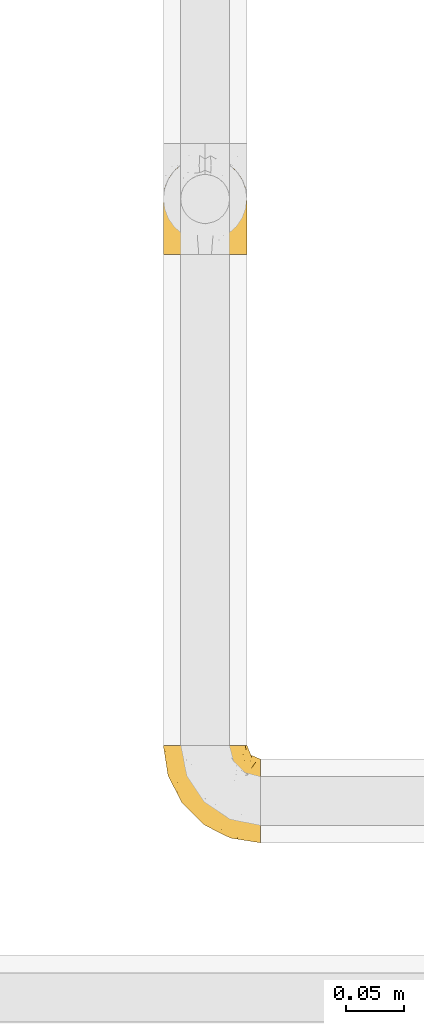
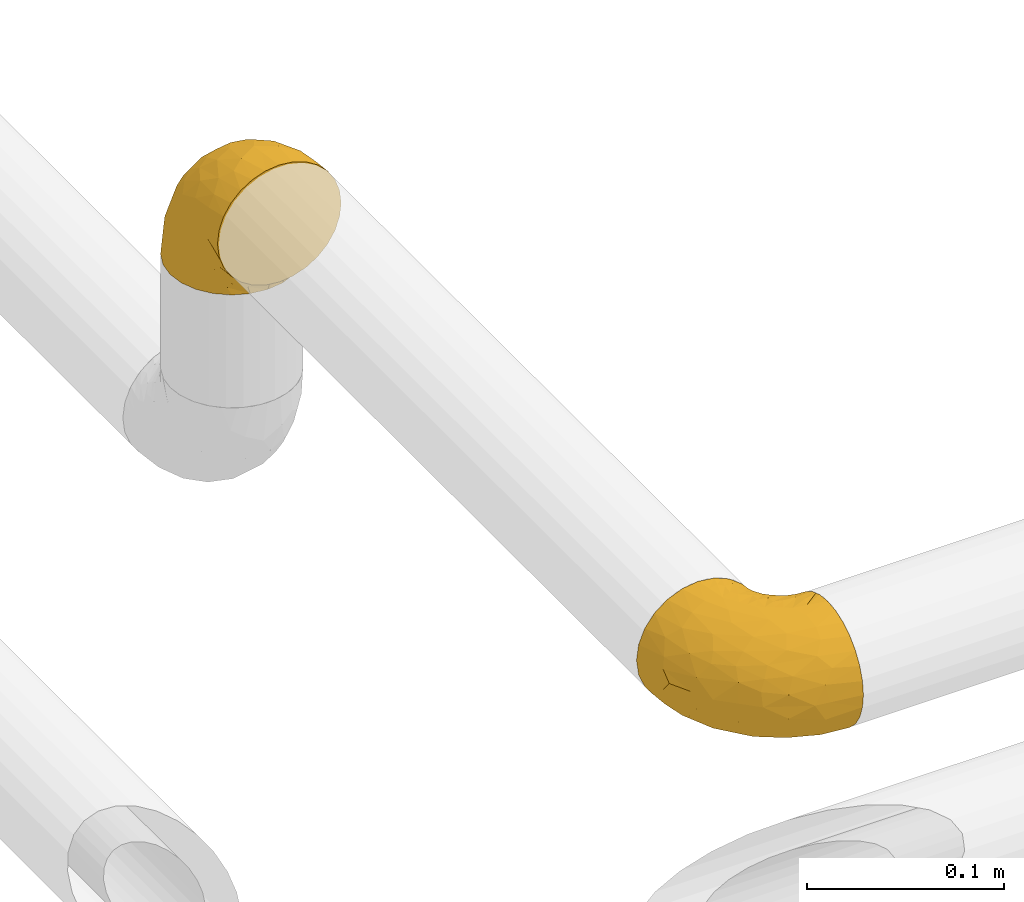
# One storey, part 8 of 39: 2 coverings.
"""IFC2X3 building model written with IfcOpenShell, lengths in millimetres."""

from ifc_helpers import new_model, entity, si_unit, converted_unit, derived_unit, direction, frame, origin, place, context, subcontext, project, spatial, faceted_brep, element, save


model = new_model("IFC2X3")

# Units and contexts
model_context = context("Model", 3, precision=0.01, world=origin(), true_north=direction((6.12303176911189e-17, 1.0)))
body_context = subcontext(model_context, "Body", "Model", "MODEL_VIEW")
ifc_project = project(units=[si_unit("LENGTHUNIT", "METRE", prefix="MILLI"), si_unit("AREAUNIT", "SQUARE_METRE"), si_unit("VOLUMEUNIT", "CUBIC_METRE"), converted_unit("PLANEANGLEUNIT", "DEGREE", entity("IfcRatioMeasure", 0.0174532925199433), si_unit("PLANEANGLEUNIT", "RADIAN"), dimensions=[0, 0, 0, 0, 0, 0, 0]), si_unit("MASSUNIT", "GRAM", prefix="KILO"), derived_unit("MASSDENSITYUNIT", [(si_unit("MASSUNIT", "GRAM", prefix="KILO"), 1), (si_unit("LENGTHUNIT", "METRE"), -3)]), derived_unit("MOMENTOFINERTIAUNIT", [(si_unit("LENGTHUNIT", "METRE"), 4)]), si_unit("TIMEUNIT", "SECOND"), si_unit("FREQUENCYUNIT", "HERTZ"), si_unit("THERMODYNAMICTEMPERATUREUNIT", "DEGREE_CELSIUS"), derived_unit("THERMALTRANSMITTANCEUNIT", [(si_unit("MASSUNIT", "GRAM", prefix="KILO"), 1), (si_unit("THERMODYNAMICTEMPERATUREUNIT", "KELVIN"), -1), (si_unit("TIMEUNIT", "SECOND"), -3)]), derived_unit("VOLUMETRICFLOWRATEUNIT", [(si_unit("LENGTHUNIT", "METRE"), 3), (si_unit("TIMEUNIT", "SECOND"), -1)]), derived_unit("MASSFLOWRATEUNIT", [(si_unit("MASSUNIT", "GRAM", prefix="KILO"), 1), (si_unit("TIMEUNIT", "SECOND"), -1)]), derived_unit("ROTATIONALFREQUENCYUNIT", [(si_unit("TIMEUNIT", "SECOND"), -1)]), si_unit("ELECTRICCURRENTUNIT", "AMPERE"), si_unit("ELECTRICVOLTAGEUNIT", "VOLT"), si_unit("POWERUNIT", "WATT"), si_unit("FORCEUNIT", "NEWTON", prefix="KILO"), si_unit("ILLUMINANCEUNIT", "LUX"), si_unit("LUMINOUSFLUXUNIT", "LUMEN"), si_unit("LUMINOUSINTENSITYUNIT", "CANDELA"), derived_unit("USERDEFINED", [(si_unit("MASSUNIT", "GRAM", prefix="KILO"), -1), (si_unit("LENGTHUNIT", "METRE"), -2), (si_unit("TIMEUNIT", "SECOND"), 3), (si_unit("LUMINOUSFLUXUNIT", "LUMEN"), 1)]), derived_unit("LINEARVELOCITYUNIT", [(si_unit("LENGTHUNIT", "METRE"), 1), (si_unit("TIMEUNIT", "SECOND"), -1)]), si_unit("PRESSUREUNIT", "PASCAL"), derived_unit("USERDEFINED", [(si_unit("LENGTHUNIT", "METRE"), -2), (si_unit("MASSUNIT", "GRAM", prefix="KILO"), 1), (si_unit("TIMEUNIT", "SECOND"), -2)]), derived_unit("LINEARFORCEUNIT", [(si_unit("MASSUNIT", "GRAM", prefix="KILO"), 1), (si_unit("LENGTHUNIT", "METRE"), 1), (si_unit("TIMEUNIT", "SECOND"), -2), (si_unit("LENGTHUNIT", "METRE"), -1)]), derived_unit("PLANARFORCEUNIT", [(si_unit("MASSUNIT", "GRAM", prefix="KILO"), 1), (si_unit("LENGTHUNIT", "METRE"), 1), (si_unit("TIMEUNIT", "SECOND"), -2), (si_unit("LENGTHUNIT", "METRE"), -2)])], contexts=[model_context])

# Site, building, storey
site_placement = place(None, origin())
site = spatial("IfcSite", under=ifc_project, at=site_placement, CompositionType="ELEMENT")
building_placement = place(site_placement, origin())
building = spatial("IfcBuilding", under=site, at=building_placement, CompositionType="ELEMENT")
storey_placement = place(building_placement, frame((0.0, 0.0, 24000.0)))
storey = spatial("IfcBuildingStorey", under=building, at=storey_placement, Name="07", CompositionType="ELEMENT", Elevation=24000.0)

# Coverings
covering_1_placement = place(storey_placement, frame((31392.2, 2072.36, 2776.36)))
element("IfcCovering", 1, at=covering_1_placement, inside=storey, Name=":ADSK_", ObjectType=":ADSK_", PredefinedType="INSULATION", context=body_context, shape_type="Brep", body=[
    faceted_brep([(74.0, 1.6, 49.6), (73.09, 1.6, 57.65), (70.41, 1.6, 65.31), (66.09, 1.6, 72.17), (60.36, 1.6, 77.9), (53.5, 1.6, 82.21), (45.85, 1.6, 84.89), (37.8, 1.6, 85.8), (29.74, 1.6, 84.89), (22.08, 1.6, 82.21), (15.22, 1.6, 77.89), (9.49, 1.6, 72.16), (5.18, 1.6, 65.3), (2.5, 1.6, 57.65), (1.6, 1.6, 49.6), (2.19, 1.6, 44.33), (2.5, 1.6, 41.54), (3.84, 1.6, 37.71), (5.18, 1.6, 33.88), (9.5, 1.6, 27.02), (15.23, 1.6, 21.29), (22.09, 1.6, 16.98), (29.74, 1.6, 14.3), (37.8, 1.6, 13.4), (45.85, 1.6, 14.3), (53.51, 1.6, 16.98), (60.37, 1.6, 21.3), (66.1, 1.6, 27.03), (70.41, 1.6, 33.89), (71.75, 1.6, 37.72), (73.09, 1.6, 41.54), (73.4, 1.6, 44.33), (28.43, 14.63, 1.6), (19.7, 18.25, 1.6), (12.2, 24.0, 1.6), (9.32, 27.75, 1.6), (6.45, 31.5, 1.6), (4.64, 35.86, 1.6), (2.83, 40.23, 1.6), (2.29, 44.31, 1.6), (1.94, 46.95, 1.6), (1.6, 49.6, 1.6), (2.83, 58.96, 1.6), (6.45, 67.7, 1.6), (12.2, 75.19, 1.6), (19.7, 80.95, 1.6), (28.43, 84.56, 1.6), (37.8, 85.8, 1.6), (47.16, 84.56, 1.6), (55.9, 80.95, 1.6), (63.39, 75.19, 1.6), (69.15, 67.7, 1.6), (72.76, 58.96, 1.6), (74.0, 49.6, 1.6), (73.3, 44.31, 1.6), (72.76, 40.23, 1.6), (70.95, 35.86, 1.6), (69.15, 31.5, 1.6), (66.27, 27.75, 1.6), (63.39, 24.0, 1.6), (55.9, 18.25, 1.6), (47.16, 14.63, 1.6), (37.8, 13.4, 1.6), (50.11, 59.61, 59.61), (37.8, 60.4, 60.4), (46.44, 51.32, 68.25), (37.8, 81.67, 27.61), (44.03, 82.49, 22.94), (37.8, 82.98, 19.4), (47.59, 73.87, 42.09), (57.17, 73.39, 33.53), (50.38, 81.11, 21.38), (58.65, 77.75, 16.47), (73.37, 16.46, 54.23), (71.27, 51.34, 38.23), (70.16, 63.37, 19.11), (66.97, 61.46, 36.76), (73.22, 54.83, 17.03), (74.0, 45.94, 19.96), (74.0, 47.42, 12.51), (74.0, 47.97, 9.78), (74.0, 48.51, 7.05), (64.86, 70.77, 21.71), (70.93, 15.75, 62.55), (45.19, 39.56, 75.89), (48.57, 21.48, 81.72), (54.32, 36.01, 74.04), (72.94, 34.58, 47.66), (74.0, 19.96, 45.94), (74.0, 23.86, 43.34), (74.0, 27.75, 40.74), (74.0, 31.64, 38.14), (74.0, 35.54, 35.54), (68.72, 46.13, 51.41), (73.34, 48.41, 30.21), (67.28, 16.74, 68.91), (61.7, 21.75, 74.03), (55.94, 16.31, 79.54), (37.8, 19.4, 82.98), (53.02, 48.77, 67.24), (57.31, 58.66, 55.48), (74.0, 7.05, 48.51), (74.0, 12.51, 47.42), (64.86, 34.87, 65.49), (59.15, 45.71, 64.99), (70.05, 30.95, 58.95), (55.98, 67.5, 45.7), (37.8, 75.69, 39.35), (63.54, 53.35, 53.72), (61.4, 64.73, 42.9), (37.8, 27.61, 81.67), (37.8, 51.09, 69.71), (37.8, 39.35, 75.69), (74.0, 38.14, 31.64), (74.0, 40.74, 27.75), (74.0, 43.34, 23.86), (37.8, 69.71, 51.09), (70.9, 30.92, 17.47), (69.2, 26.47, 18.36), (65.83, 24.1, 12.71), (73.31, 42.08, 7.84), (67.07, 27.56, 7.85), (62.53, 22.68, 6.14), (52.3, 12.9, 11.2), (54.94, 10.56, 14.99), (46.54, 9.38, 11.85), (72.14, 25.09, 29.62), (70.14, 24.56, 23.5), (73.22, 30.86, 29.66), (59.32, 15.4, 14.49), (56.36, 16.56, 9.51), (48.99, 14.21, 6.6), (58.36, 19.1, 6.61), (66.05, 6.65, 26.46), (61.56, 9.22, 20.83), (68.98, 13.56, 28.69), (73.26, 10.43, 41.38), (70.05, 32.68, 7.16), (73.39, 40.02, 16.97), (70.87, 33.01, 12.64), (61.17, 13.09, 18.4), (71.9, 11.85, 35.97), (65.19, 20.93, 16.38), (37.8, 6.64, 11.31), (46.04, 5.68, 13.68), (52.15, 5.7, 15.78), (66.57, 14.76, 24.06), (37.8, 9.94, 9.94), (73.34, 25.2, 35.3), (72.91, 19.66, 36.41), (37.8, 11.31, 6.64), (72.75, 39.13, 10.52), (66.28, 18.54, 20.86), (73.17, 37.21, 20.48), (72.08, 30.49, 23.69), (17.23, 19.1, 6.61), (26.6, 14.22, 6.59), (13.06, 22.68, 6.13), (1.6, 7.05, 48.51), (1.6, 12.51, 47.42), (29.56, 5.68, 13.67), (20.66, 10.57, 14.98), (23.45, 5.7, 15.78), (14.04, 9.22, 20.82), (1.6, 49.05, 4.32), (1.6, 47.42, 12.51), (1.6, 48.51, 7.05), (19.23, 16.56, 9.51), (23.3, 12.9, 11.19), (16.29, 15.39, 14.48), (8.09, 27.52, 10.19), (4.72, 33.0, 12.64), (5.54, 32.67, 7.16), (3.69, 11.86, 35.96), (2.84, 39.13, 10.52), (2.42, 37.21, 20.47), (4.69, 30.92, 17.47), (3.51, 30.49, 23.68), (2.2, 40.02, 16.97), (29.05, 9.38, 11.85), (2.29, 42.08, 7.84), (9.55, 6.65, 26.45), (14.43, 13.09, 18.39), (2.33, 10.43, 41.37), (9.32, 18.54, 20.85), (3.45, 25.08, 29.62), (5.45, 24.56, 23.5), (10.41, 20.93, 16.36), (2.81, 19.57, 35.87), (6.62, 13.56, 28.67), (1.6, 19.96, 45.94), (9.76, 24.1, 12.7), (9.03, 14.76, 24.04), (1.6, 40.74, 27.75), (4.15, 20.0, 30.95), (2.17, 25.27, 35.8), (1.6, 23.86, 43.34), (2.37, 30.85, 29.66), (1.6, 45.94, 19.96), (1.6, 43.34, 23.86), (6.39, 26.46, 18.36), (1.6, 38.14, 31.64), (1.6, 27.75, 40.74), (1.6, 35.54, 35.54), (1.6, 31.64, 38.14), (4.32, 51.33, 38.23), (2.37, 54.83, 17.03), (2.25, 48.41, 30.2), (16.43, 45.7, 64.98), (18.27, 58.67, 55.47), (12.04, 53.34, 53.71), (8.62, 61.46, 36.76), (6.87, 46.13, 51.4), (10.72, 34.86, 65.48), (2.64, 34.58, 47.66), (25.48, 59.61, 59.61), (19.59, 67.49, 45.69), (5.43, 63.37, 19.11), (31.57, 82.49, 22.94), (25.21, 81.11, 21.39), (5.53, 30.94, 58.94), (16.94, 77.75, 16.47), (10.73, 70.77, 21.71), (18.42, 73.39, 33.54), (21.26, 36.01, 74.04), (27.01, 21.48, 81.72), (30.39, 39.57, 75.89), (2.22, 16.45, 54.23), (13.88, 21.75, 74.02), (8.3, 16.74, 68.9), (28.0, 73.87, 42.09), (29.14, 51.31, 68.25), (22.56, 48.77, 67.24), (19.64, 16.32, 79.54), (14.18, 64.71, 42.91), (4.66, 15.75, 62.54)], [[[0, 1, 2, 3, 4, 5, 6, 7, 8, 9, 10, 11, 12, 13, 14, 15, 16, 17, 18, 19, 20, 21, 22, 23, 24, 25, 26, 27, 28, 29, 30, 31]], [[32, 33, 34, 35, 36, 37, 38, 39, 40, 41, 42, 43, 44, 45, 46, 47, 48, 49, 50, 51, 52, 53, 54, 55, 56, 57, 58, 59, 60, 61, 62]], [[63, 64, 65]], [[66, 67, 68]], [[69, 70, 71]], [[71, 70, 72]], [[73, 1, 0]], [[74, 75, 76]], [[49, 48, 71]], [[77, 78, 79, 80, 81, 53]], [[50, 82, 51]], [[72, 50, 49]], [[2, 1, 83]], [[84, 85, 86]], [[87, 88, 89, 90, 91, 92]], [[53, 52, 77]], [[93, 74, 76]], [[5, 85, 6]], [[94, 78, 77]], [[95, 3, 2]], [[95, 96, 3]], [[75, 51, 82]], [[85, 5, 97]], [[50, 72, 82]], [[97, 5, 4]], [[85, 98, 6]], [[94, 87, 92]], [[74, 77, 75]], [[99, 100, 63]], [[96, 4, 3]], [[73, 0, 101, 102, 88]], [[96, 103, 104]], [[48, 68, 67]], [[84, 99, 65]], [[105, 83, 73]], [[105, 95, 83]], [[100, 106, 63]], [[86, 96, 104]], [[97, 86, 85]], [[67, 107, 69]], [[100, 108, 109]], [[84, 110, 85]], [[93, 87, 74]], [[96, 95, 103]], [[69, 71, 67]], [[70, 69, 106]], [[4, 96, 97]], [[86, 97, 96]], [[83, 95, 2]], [[103, 95, 105]], [[93, 103, 105]], [[103, 108, 104]], [[75, 77, 52]], [[94, 77, 74]], [[51, 75, 52]], [[75, 82, 76]], [[109, 82, 70]], [[93, 76, 108]], [[88, 87, 73]], [[105, 73, 87]], [[84, 86, 99]], [[84, 111, 112, 110]], [[98, 85, 110]], [[98, 7, 6]], [[73, 83, 1]], [[71, 72, 49]], [[82, 72, 70]], [[87, 94, 74]], [[94, 92, 113, 114, 115, 78]], [[48, 47, 68]], [[48, 67, 71]], [[100, 104, 108]], [[99, 86, 104]], [[109, 108, 76]], [[100, 109, 106]], [[82, 109, 76]], [[106, 109, 70]], [[100, 99, 104]], [[99, 63, 65]], [[69, 116, 63]], [[111, 84, 65]], [[64, 63, 116]], [[64, 111, 65]], [[63, 106, 69]], [[103, 93, 108]], [[87, 93, 105]], [[107, 67, 66]], [[107, 116, 69]], [[117, 118, 119]], [[80, 120, 55]], [[121, 119, 122]], [[120, 56, 55]], [[123, 124, 125]], [[126, 127, 128]], [[101, 0, 31, 30, 102]], [[123, 129, 124]], [[130, 123, 131]], [[60, 122, 132]], [[133, 134, 135]], [[29, 28, 136]], [[132, 61, 60]], [[122, 60, 59]], [[137, 138, 139]], [[124, 129, 140]], [[133, 27, 26]], [[132, 131, 61]], [[141, 136, 28]], [[102, 29, 136]], [[119, 118, 142]], [[58, 137, 121]], [[141, 28, 27]], [[54, 53, 81, 80, 55]], [[23, 143, 144]], [[24, 145, 25]], [[25, 145, 134]], [[26, 25, 134]], [[135, 134, 146]], [[125, 143, 147]], [[124, 144, 125]], [[148, 90, 149]], [[124, 145, 144]], [[150, 125, 147]], [[151, 57, 56]], [[138, 78, 115]], [[131, 62, 61]], [[133, 141, 27]], [[127, 126, 152]], [[141, 135, 149]], [[149, 89, 141]], [[120, 78, 151]], [[115, 153, 138]], [[138, 137, 151]], [[78, 120, 80, 79]], [[151, 56, 120]], [[154, 114, 113]], [[153, 117, 139]], [[145, 24, 144]], [[134, 145, 124]], [[126, 91, 148]], [[146, 126, 135]], [[23, 144, 24]], [[143, 125, 144]], [[131, 125, 150]], [[129, 123, 130]], [[142, 130, 119]], [[124, 140, 134]], [[125, 131, 123]], [[62, 131, 150]], [[129, 152, 140]], [[146, 140, 152]], [[127, 152, 142]], [[153, 115, 114]], [[117, 153, 154]], [[118, 117, 154]], [[121, 117, 119]], [[139, 138, 153]], [[78, 138, 151]], [[127, 118, 154]], [[118, 127, 142]], [[152, 129, 142]], [[130, 142, 129]], [[102, 30, 29]], [[141, 88, 136]], [[88, 102, 136]], [[134, 133, 26]], [[141, 133, 135]], [[121, 122, 59]], [[132, 119, 130]], [[121, 59, 58]], [[121, 139, 117]], [[137, 58, 57]], [[151, 137, 57]], [[121, 137, 139]], [[119, 132, 122]], [[132, 130, 131]], [[140, 146, 134]], [[126, 146, 152]], [[89, 149, 90]], [[89, 88, 141]], [[148, 135, 126]], [[135, 148, 149]], [[114, 154, 153]], [[126, 128, 91]], [[91, 90, 148]], [[92, 128, 113]], [[128, 127, 154]], [[113, 128, 154]], [[91, 128, 92]], [[155, 32, 156]], [[33, 157, 34]], [[62, 150, 156]], [[15, 14, 158, 159, 16]], [[160, 23, 22]], [[161, 162, 163]], [[164, 41, 40, 39, 38, 165, 166]], [[167, 168, 169]], [[157, 170, 34]], [[171, 172, 170]], [[18, 173, 19]], [[174, 37, 36]], [[175, 176, 177]], [[178, 171, 175]], [[147, 179, 150]], [[168, 179, 161]], [[161, 160, 162]], [[162, 160, 22]], [[38, 37, 180]], [[20, 19, 181]], [[21, 20, 163]], [[161, 182, 169]], [[18, 183, 173]], [[184, 185, 186]], [[169, 187, 167]], [[188, 189, 173]], [[159, 190, 183]], [[17, 159, 183]], [[156, 179, 168]], [[191, 157, 155]], [[192, 163, 189]], [[21, 162, 22]], [[147, 143, 179]], [[181, 163, 20]], [[193, 175, 177]], [[178, 172, 171]], [[167, 156, 168]], [[185, 194, 195]], [[181, 173, 189]], [[173, 196, 188]], [[197, 186, 185]], [[198, 165, 180]], [[180, 165, 38]], [[199, 178, 175]], [[37, 174, 180]], [[198, 180, 174]], [[175, 193, 199]], [[177, 176, 200]], [[163, 162, 21]], [[160, 161, 179]], [[192, 185, 184]], [[194, 189, 188]], [[179, 143, 160]], [[23, 160, 143]], [[169, 168, 161]], [[155, 156, 167]], [[182, 161, 163]], [[184, 186, 187]], [[62, 156, 32]], [[179, 156, 150]], [[192, 182, 163]], [[184, 169, 182]], [[176, 175, 171]], [[174, 178, 198]], [[197, 201, 177]], [[170, 176, 171]], [[200, 176, 191]], [[198, 178, 199]], [[178, 174, 172]], [[187, 200, 191]], [[200, 187, 186]], [[167, 187, 191]], [[169, 184, 187]], [[173, 183, 190]], [[17, 16, 159]], [[173, 181, 19]], [[163, 181, 189]], [[155, 157, 33]], [[170, 157, 191]], [[176, 170, 191]], [[172, 36, 35]], [[36, 172, 174]], [[34, 170, 35]], [[170, 172, 35]], [[32, 155, 33]], [[191, 155, 167]], [[192, 189, 194]], [[182, 192, 184]], [[177, 186, 197]], [[183, 18, 17]], [[196, 173, 190]], [[196, 202, 188]], [[201, 193, 177]], [[200, 186, 177]], [[188, 195, 194]], [[203, 197, 204]], [[188, 202, 195]], [[192, 194, 185]], [[202, 204, 195]], [[185, 195, 204]], [[204, 197, 185]], [[201, 197, 203]], [[205, 206, 207]], [[208, 209, 210]], [[210, 211, 212]], [[210, 213, 208]], [[214, 203, 204, 202, 196, 190]], [[206, 41, 164, 166, 165, 198]], [[215, 216, 209]], [[206, 217, 42]], [[218, 46, 219]], [[207, 214, 205]], [[212, 214, 220]], [[221, 219, 45]], [[45, 219, 46]], [[221, 222, 223]], [[224, 225, 226]], [[222, 44, 43]], [[222, 217, 211]], [[220, 214, 227]], [[227, 190, 159, 158, 14]], [[217, 43, 42]], [[14, 13, 227]], [[225, 9, 8]], [[10, 228, 11]], [[11, 229, 12]], [[208, 213, 228]], [[228, 229, 11]], [[230, 219, 223]], [[231, 232, 226]], [[231, 64, 215]], [[225, 233, 9]], [[229, 213, 220]], [[233, 10, 9]], [[110, 225, 98]], [[41, 206, 42]], [[222, 211, 234]], [[224, 228, 233]], [[225, 8, 98]], [[221, 45, 44]], [[226, 110, 112, 111]], [[12, 229, 235]], [[46, 218, 68]], [[230, 107, 218]], [[223, 234, 216]], [[107, 66, 218]], [[224, 233, 225]], [[228, 10, 233]], [[213, 229, 228]], [[235, 229, 220]], [[208, 228, 224]], [[212, 213, 210]], [[207, 206, 198]], [[205, 211, 217]], [[205, 217, 206]], [[43, 217, 222]], [[212, 211, 205]], [[210, 209, 234]], [[227, 13, 235]], [[214, 190, 227]], [[110, 226, 225]], [[232, 231, 215]], [[8, 7, 98]], [[227, 235, 220]], [[13, 12, 235]], [[222, 221, 44]], [[219, 221, 223]], [[207, 198, 199, 193, 201, 203]], [[214, 207, 203]], [[68, 218, 66]], [[68, 47, 46]], [[230, 218, 219]], [[224, 232, 208]], [[208, 232, 209]], [[216, 215, 230]], [[210, 234, 211]], [[216, 234, 209]], [[222, 234, 223]], [[226, 232, 224]], [[209, 232, 215]], [[226, 111, 231]], [[64, 116, 215]], [[231, 111, 64]], [[116, 230, 215]], [[230, 223, 216]], [[214, 212, 205]], [[213, 212, 220]], [[230, 116, 107]]]),
])
covering_2_placement = place(storey_placement, frame((31392.21, 1563.38, 2788.16)))
element("IfcCovering", 2, at=covering_2_placement, inside=storey, Name=":ADSK_", ObjectType=":ADSK_", PredefinedType="INSULATION", context=body_context, shape_type="Brep", body=[
    faceted_brep([(85.72, 37.8, 74.09), (85.72, 29.74, 73.18), (85.73, 22.08, 70.5), (85.74, 15.22, 66.19), (85.75, 9.49, 60.46), (85.76, 5.18, 53.59), (85.78, 2.5, 45.94), (85.8, 1.6, 37.89), (85.81, 2.5, 29.83), (85.83, 5.18, 22.18), (85.84, 9.5, 15.32), (85.85, 15.23, 9.58), (85.86, 22.09, 5.27), (85.87, 29.74, 2.6), (85.87, 37.8, 1.69), (85.87, 43.06, 2.28), (85.87, 45.85, 2.6), (85.86, 49.68, 3.94), (85.86, 53.51, 5.28), (85.85, 60.37, 9.59), (85.84, 66.1, 15.33), (85.83, 70.41, 22.19), (85.81, 73.09, 29.84), (85.8, 74.0, 37.89), (85.78, 73.09, 45.95), (85.76, 70.41, 53.6), (85.75, 66.09, 60.47), (85.74, 60.36, 66.2), (85.73, 53.5, 70.51), (85.73, 49.67, 71.85), (85.72, 45.85, 73.18), (85.72, 43.06, 73.5), (72.78, 85.8, 28.5), (69.18, 85.8, 19.76), (63.44, 85.8, 12.25), (59.7, 85.8, 9.37), (55.96, 85.8, 6.48), (51.6, 85.8, 4.66), (47.23, 85.8, 2.85), (43.15, 85.8, 2.3), (40.51, 85.8, 1.95), (37.87, 85.8, 1.6), (28.5, 85.8, 2.81), (19.76, 85.8, 6.41), (12.25, 85.8, 12.15), (6.48, 85.8, 19.63), (2.85, 85.8, 28.36), (1.6, 85.8, 37.72), (2.81, 85.8, 47.09), (6.41, 85.8, 55.83), (12.15, 85.8, 63.34), (19.63, 85.8, 69.11), (28.36, 85.8, 72.74), (37.72, 85.8, 74.0), (43.01, 85.8, 73.31), (47.09, 85.8, 72.78), (51.46, 85.8, 70.98), (55.83, 85.8, 69.18), (59.59, 85.8, 66.31), (63.34, 85.8, 63.44), (69.11, 85.8, 55.96), (72.74, 85.8, 47.23), (74.0, 85.8, 37.87), (27.76, 27.78, 50.09), (26.99, 26.99, 37.77), (36.06, 19.15, 46.43), (5.72, 59.78, 37.73), (4.89, 64.45, 43.96), (4.42, 67.99, 37.73), (13.5, 45.3, 47.54), (13.96, 53.86, 57.12), (6.25, 66.01, 50.31), (9.6, 70.92, 58.59), (70.86, 33.16, 73.44), (35.99, 49.16, 71.27), (23.96, 68.28, 70.14), (25.87, 50.64, 66.95), (32.49, 70.36, 73.21), (41.38, 67.43, 74.0), (39.89, 74.88, 74.0), (39.35, 77.61, 74.0), (38.81, 80.34, 74.0), (16.57, 65.68, 64.82), (71.57, 24.84, 71.0), (47.82, 11.5, 45.21), (65.89, 5.67, 48.62), (51.34, 13.35, 54.35), (52.74, 39.73, 72.97), (67.35, 41.45, 74.05), (63.46, 44.05, 74.05), (59.57, 46.65, 74.04), (55.67, 49.25, 74.03), (51.78, 51.85, 74.02), (41.19, 35.98, 68.73), (38.91, 57.18, 73.34), (70.59, 18.48, 67.34), (65.59, 13.36, 61.76), (71.04, 7.85, 56.0), (67.99, 4.42, 37.86), (38.59, 20.15, 53.02), (28.69, 31.91, 57.29), (80.26, 38.88, 74.08), (74.81, 39.97, 74.07), (52.47, 21.9, 64.89), (41.64, 22.4, 59.16), (56.38, 28.44, 70.09), (19.86, 41.69, 55.95), (11.7, 48.04, 37.74), (33.99, 33.67, 63.53), (22.61, 44.49, 61.37), (59.78, 5.72, 37.84), (36.3, 17.68, 37.79), (48.04, 11.7, 37.82), (49.18, 55.75, 74.02), (46.58, 59.64, 74.01), (43.98, 63.53, 74.01), (17.68, 36.3, 37.75), (56.4, 69.92, 70.93), (60.86, 69.03, 69.25), (63.24, 74.68, 65.88), (45.24, 79.55, 73.32), (59.77, 79.54, 67.12), (64.66, 81.25, 62.58), (74.46, 76.19, 52.37), (76.79, 72.4, 55.02), (77.99, 75.54, 46.62), (56.83, 63.7, 72.12), (50.11, 66.91, 73.19), (71.95, 72.9, 59.39), (70.8, 77.88, 56.43), (73.15, 80.8, 49.06), (68.25, 80.78, 58.42), (80.68, 60.93, 66.14), (78.12, 66.56, 61.64), (73.77, 58.7, 69.05), (76.89, 46.01, 73.34), (54.65, 80.23, 70.09), (47.3, 70.42, 73.4), (54.32, 74.75, 70.91), (74.25, 68.99, 61.25), (75.47, 51.42, 71.98), (66.41, 71.01, 65.25), (80.75, 76.08, 37.88), (81.7, 73.72, 46.13), (81.66, 71.61, 52.24), (72.58, 63.33, 66.64), (77.45, 77.45, 37.87), (62.12, 52.1, 73.39), (67.66, 50.98, 72.97), (76.08, 80.75, 37.87), (48.19, 76.87, 72.77), (62.76, 63.89, 70.19), (62.24, 57.77, 72.19), (68.8, 66.53, 66.34), (56.46, 57.73, 73.26), (68.33, 80.78, 17.3), (73.19, 80.8, 26.67), (64.76, 81.26, 13.12), (80.41, 38.88, 1.68), (74.95, 39.97, 1.67), (81.73, 73.72, 29.65), (76.86, 72.41, 20.74), (81.72, 71.61, 23.53), (78.22, 66.57, 14.13), (38.41, 83.07, 1.6), (40.04, 74.88, 1.6), (38.95, 80.34, 1.6), (70.87, 77.88, 19.29), (74.52, 76.2, 23.38), (72.04, 72.91, 16.36), (59.93, 77.2, 8.13), (54.45, 74.75, 4.75), (54.78, 80.23, 5.57), (75.6, 51.43, 3.77), (48.33, 76.87, 2.86), (50.25, 66.92, 2.45), (56.53, 69.93, 4.73), (56.97, 63.71, 3.55), (47.44, 70.42, 2.22), (78.03, 75.54, 29.13), (45.38, 79.55, 2.3), (80.79, 60.94, 9.63), (74.35, 69.0, 14.5), (77.03, 46.02, 2.41), (68.91, 66.54, 9.38), (62.38, 57.77, 3.5), (62.89, 63.89, 5.5), (66.52, 71.03, 10.47), (67.89, 51.53, 2.87), (73.89, 58.72, 6.69), (67.5, 41.45, 1.65), (63.35, 74.69, 9.81), (72.69, 63.35, 9.1), (56.61, 57.73, 2.41), (67.46, 56.44, 4.21), (62.19, 51.59, 2.21), (63.61, 44.05, 1.65), (46.72, 59.64, 1.61), (49.33, 55.75, 1.62), (41.52, 67.43, 1.6), (44.12, 63.53, 1.61), (60.99, 69.03, 6.44), (59.71, 46.65, 1.64), (51.93, 51.85, 1.62), (55.82, 49.25, 1.63), (36.12, 49.16, 4.31), (32.63, 70.36, 2.36), (39.05, 57.19, 2.25), (41.73, 22.41, 16.44), (28.76, 31.92, 18.26), (34.1, 33.68, 12.04), (25.99, 50.63, 8.59), (41.33, 35.99, 6.87), (52.58, 21.91, 10.75), (52.88, 39.73, 2.67), (27.81, 27.78, 25.46), (19.94, 41.7, 19.56), (24.09, 68.28, 5.4), (4.92, 64.45, 31.5), (6.3, 66.0, 25.15), (56.51, 28.45, 5.57), (9.69, 70.92, 16.89), (16.68, 65.68, 10.68), (14.04, 53.85, 18.38), (51.41, 13.35, 21.29), (65.93, 5.67, 27.07), (47.84, 11.5, 30.41), (71.01, 33.16, 2.28), (65.69, 13.37, 13.94), (70.71, 18.49, 8.37), (13.54, 45.3, 27.95), (36.1, 19.14, 29.14), (38.65, 20.15, 22.56), (71.11, 7.85, 19.71), (22.73, 44.48, 14.15), (71.7, 24.85, 4.72)], [[[0, 1, 2, 3, 4, 5, 6, 7, 8, 9, 10, 11, 12, 13, 14, 15, 16, 17, 18, 19, 20, 21, 22, 23, 24, 25, 26, 27, 28, 29, 30, 31]], [[32, 33, 34, 35, 36, 37, 38, 39, 40, 41, 42, 43, 44, 45, 46, 47, 48, 49, 50, 51, 52, 53, 54, 55, 56, 57, 58, 59, 60, 61, 62]], [[63, 64, 65]], [[66, 67, 68]], [[69, 70, 71]], [[71, 70, 72]], [[73, 1, 0]], [[74, 75, 76]], [[49, 48, 71]], [[77, 78, 79, 80, 81, 53]], [[50, 82, 51]], [[72, 50, 49]], [[2, 1, 83]], [[84, 85, 86]], [[87, 88, 89, 90, 91, 92]], [[53, 52, 77]], [[93, 74, 76]], [[5, 85, 6]], [[94, 78, 77]], [[95, 3, 2]], [[95, 96, 3]], [[75, 51, 82]], [[85, 5, 97]], [[50, 72, 82]], [[97, 5, 4]], [[85, 98, 6]], [[94, 87, 92]], [[74, 77, 75]], [[99, 100, 63]], [[96, 4, 3]], [[73, 0, 101, 102, 88]], [[96, 103, 104]], [[48, 68, 67]], [[84, 99, 65]], [[105, 83, 73]], [[105, 95, 83]], [[100, 106, 63]], [[86, 96, 104]], [[97, 86, 85]], [[67, 107, 69]], [[100, 108, 109]], [[84, 110, 85]], [[93, 87, 74]], [[96, 95, 103]], [[69, 71, 67]], [[70, 69, 106]], [[4, 96, 97]], [[86, 97, 96]], [[83, 95, 2]], [[103, 95, 105]], [[93, 103, 105]], [[103, 108, 104]], [[75, 77, 52]], [[94, 77, 74]], [[51, 75, 52]], [[75, 82, 76]], [[109, 82, 70]], [[93, 76, 108]], [[88, 87, 73]], [[105, 73, 87]], [[84, 86, 99]], [[84, 111, 112, 110]], [[98, 85, 110]], [[98, 7, 6]], [[73, 83, 1]], [[71, 72, 49]], [[82, 72, 70]], [[87, 94, 74]], [[94, 92, 113, 114, 115, 78]], [[48, 47, 68]], [[48, 67, 71]], [[100, 104, 108]], [[99, 86, 104]], [[109, 108, 76]], [[100, 109, 106]], [[82, 109, 76]], [[106, 109, 70]], [[100, 99, 104]], [[99, 63, 65]], [[69, 116, 63]], [[111, 84, 65]], [[64, 63, 116]], [[64, 111, 65]], [[63, 106, 69]], [[103, 93, 108]], [[87, 93, 105]], [[107, 67, 66]], [[107, 116, 69]], [[117, 118, 119]], [[80, 120, 55]], [[121, 119, 122]], [[120, 56, 55]], [[123, 124, 125]], [[114, 126, 127]], [[101, 0, 31, 30, 102]], [[123, 128, 124]], [[129, 123, 130]], [[60, 122, 131]], [[132, 133, 134]], [[29, 28, 135]], [[131, 61, 60]], [[122, 60, 59]], [[136, 137, 138]], [[124, 128, 139]], [[132, 27, 26]], [[131, 130, 61]], [[140, 135, 28]], [[102, 29, 135]], [[119, 118, 141]], [[58, 136, 121]], [[140, 28, 27]], [[54, 53, 81, 80, 55]], [[23, 142, 143]], [[24, 144, 25]], [[25, 144, 133]], [[26, 25, 133]], [[134, 133, 145]], [[125, 142, 146]], [[124, 143, 125]], [[147, 90, 148]], [[124, 144, 143]], [[149, 125, 146]], [[150, 57, 56]], [[137, 78, 115]], [[130, 62, 61]], [[132, 140, 27]], [[151, 152, 153]], [[140, 134, 148]], [[148, 89, 140]], [[120, 78, 150]], [[115, 127, 137]], [[137, 136, 150]], [[78, 120, 80, 79]], [[150, 56, 120]], [[91, 154, 92]], [[127, 117, 138]], [[144, 24, 143]], [[133, 144, 124]], [[152, 91, 147]], [[145, 152, 134]], [[23, 143, 24]], [[142, 125, 143]], [[130, 125, 149]], [[128, 123, 129]], [[141, 129, 119]], [[124, 139, 133]], [[125, 130, 123]], [[62, 130, 149]], [[128, 153, 139]], [[145, 139, 153]], [[92, 154, 113]], [[127, 115, 114]], [[117, 127, 126]], [[118, 117, 126]], [[121, 117, 119]], [[138, 137, 127]], [[78, 137, 150]], [[151, 118, 126]], [[118, 151, 141]], [[153, 128, 141]], [[129, 141, 128]], [[102, 30, 29]], [[140, 88, 135]], [[88, 102, 135]], [[133, 132, 26]], [[140, 132, 134]], [[121, 122, 59]], [[131, 119, 129]], [[121, 59, 58]], [[121, 138, 117]], [[136, 58, 57]], [[150, 136, 57]], [[121, 136, 138]], [[119, 131, 122]], [[131, 129, 130]], [[139, 145, 133]], [[152, 145, 153]], [[89, 148, 90]], [[89, 88, 140]], [[147, 134, 152]], [[134, 147, 148]], [[126, 114, 113]], [[152, 154, 91]], [[91, 90, 147]], [[151, 153, 141]], [[154, 151, 126]], [[151, 154, 152]], [[113, 154, 126]], [[155, 32, 156]], [[33, 157, 34]], [[62, 149, 156]], [[15, 14, 158, 159, 16]], [[160, 23, 22]], [[161, 162, 163]], [[164, 41, 40, 39, 38, 165, 166]], [[167, 168, 169]], [[157, 170, 34]], [[171, 172, 170]], [[18, 173, 19]], [[174, 37, 36]], [[175, 176, 177]], [[178, 171, 175]], [[146, 179, 149]], [[168, 179, 161]], [[161, 160, 162]], [[162, 160, 22]], [[38, 37, 180]], [[20, 19, 181]], [[21, 20, 163]], [[161, 182, 169]], [[18, 183, 173]], [[184, 185, 186]], [[169, 187, 167]], [[188, 189, 173]], [[159, 190, 183]], [[17, 159, 183]], [[156, 179, 168]], [[191, 157, 155]], [[192, 163, 189]], [[21, 162, 22]], [[146, 142, 179]], [[181, 163, 20]], [[177, 186, 193]], [[178, 172, 171]], [[167, 156, 168]], [[185, 194, 195]], [[181, 173, 189]], [[173, 196, 188]], [[197, 177, 198]], [[199, 165, 180]], [[180, 165, 38]], [[200, 178, 175]], [[37, 174, 180]], [[199, 180, 174]], [[175, 197, 200]], [[177, 176, 201]], [[163, 162, 21]], [[160, 161, 179]], [[192, 185, 184]], [[194, 189, 188]], [[179, 142, 160]], [[23, 160, 142]], [[169, 168, 161]], [[155, 156, 167]], [[182, 161, 163]], [[184, 186, 187]], [[62, 156, 32]], [[179, 156, 149]], [[192, 182, 163]], [[184, 169, 182]], [[176, 175, 171]], [[174, 178, 199]], [[197, 175, 177]], [[170, 176, 171]], [[201, 176, 191]], [[199, 178, 200]], [[178, 174, 172]], [[187, 201, 191]], [[201, 187, 186]], [[167, 187, 191]], [[169, 184, 187]], [[173, 183, 190]], [[17, 16, 159]], [[173, 181, 19]], [[163, 181, 189]], [[155, 157, 33]], [[170, 157, 191]], [[176, 170, 191]], [[35, 170, 172]], [[35, 172, 36]], [[34, 170, 35]], [[174, 36, 172]], [[32, 155, 33]], [[191, 155, 167]], [[192, 189, 194]], [[182, 192, 184]], [[193, 198, 177]], [[183, 18, 17]], [[196, 173, 190]], [[196, 202, 188]], [[193, 186, 185]], [[201, 186, 177]], [[188, 195, 194]], [[203, 193, 204]], [[188, 202, 195]], [[192, 194, 185]], [[202, 204, 195]], [[185, 195, 204]], [[204, 193, 185]], [[198, 193, 203]], [[205, 206, 207]], [[208, 209, 210]], [[210, 211, 212]], [[210, 213, 208]], [[214, 203, 204, 202, 196, 190]], [[206, 41, 164, 166, 165, 199]], [[215, 216, 209]], [[206, 217, 42]], [[218, 46, 219]], [[207, 214, 205]], [[212, 214, 220]], [[221, 219, 45]], [[45, 219, 46]], [[221, 222, 223]], [[224, 225, 226]], [[222, 44, 43]], [[222, 217, 211]], [[220, 214, 227]], [[227, 190, 159, 158, 14]], [[217, 43, 42]], [[14, 13, 227]], [[225, 9, 8]], [[10, 228, 11]], [[11, 229, 12]], [[208, 213, 228]], [[228, 229, 11]], [[230, 219, 223]], [[231, 232, 226]], [[231, 64, 215]], [[225, 233, 9]], [[229, 213, 220]], [[233, 10, 9]], [[110, 225, 98]], [[41, 206, 42]], [[222, 211, 234]], [[224, 228, 233]], [[225, 8, 98]], [[221, 45, 44]], [[226, 110, 112, 111]], [[12, 229, 235]], [[46, 218, 68]], [[230, 107, 218]], [[223, 234, 216]], [[107, 66, 218]], [[224, 233, 225]], [[228, 10, 233]], [[213, 229, 228]], [[235, 229, 220]], [[208, 228, 224]], [[212, 213, 210]], [[207, 206, 199]], [[205, 211, 217]], [[205, 217, 206]], [[43, 217, 222]], [[212, 211, 205]], [[210, 209, 234]], [[227, 13, 235]], [[214, 190, 227]], [[110, 226, 225]], [[232, 231, 215]], [[8, 7, 98]], [[227, 235, 220]], [[13, 12, 235]], [[222, 221, 44]], [[219, 221, 223]], [[207, 199, 200, 197, 198, 203]], [[214, 207, 203]], [[68, 218, 66]], [[68, 47, 46]], [[230, 218, 219]], [[224, 232, 208]], [[208, 232, 209]], [[216, 215, 230]], [[210, 234, 211]], [[216, 234, 209]], [[222, 234, 223]], [[226, 232, 224]], [[209, 232, 215]], [[226, 111, 231]], [[64, 116, 215]], [[231, 111, 64]], [[116, 230, 215]], [[230, 223, 216]], [[214, 212, 205]], [[213, 212, 220]], [[230, 116, 107]]]),
])

save(model, "model.ifc")
